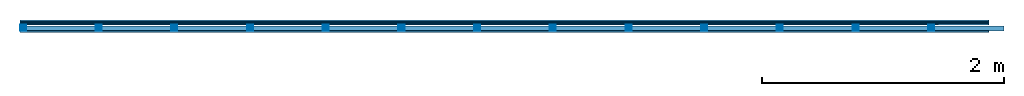
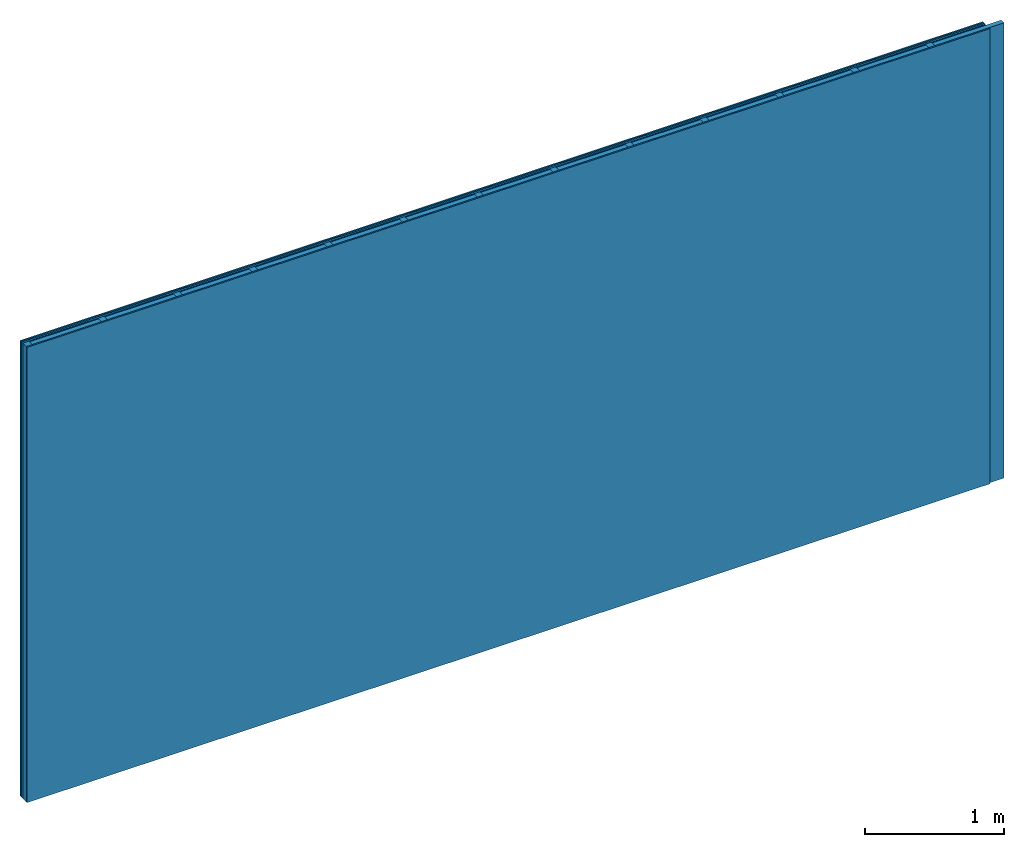
# One storey: 4 plates, 2 members, 1 element without a shape of its own.
"""IFC4 building model written with IfcOpenShell, lengths in metres."""

from ifc_helpers import new_model, si_unit, derived_unit, direction, frame, frame_2d, origin, origin_with_axes, place, context, project, spatial, rectangle, extrude, material, layer, layer_set, type_object, element, aggregate, save


model = new_model("IFC4")

# Units and contexts
plan_context = context("Plan", 3, precision=1e-05, world=origin(), true_north=direction((0.0, 1.0)))
model_context = context("Model", 3, precision=1e-05, world=origin(), true_north=direction((0.0, 1.0)))
ifc_project = project(units=[si_unit("LENGTHUNIT", "METRE"), derived_unit("SOUNDPRESSUREUNIT", [(si_unit("PRESSUREUNIT", "PASCAL", prefix="MICRO"), 0)]), si_unit("ENERGYUNIT", "JOULE", prefix="MEGA"), si_unit("MASSUNIT", "GRAM", prefix="KILO"), derived_unit("THERMALTRANSMITTANCEUNIT", [(si_unit("POWERUNIT", "WATT"), 1), (si_unit("AREAUNIT", "SQUARE_METRE"), -1), (si_unit("THERMODYNAMICTEMPERATUREUNIT", "KELVIN"), -1)]), derived_unit("AREADENSITYUNIT", [(si_unit("MASSUNIT", "GRAM", prefix="KILO"), 1), (si_unit("AREAUNIT", "SQUARE_METRE"), -1)]), derived_unit("USERDEFINED", [(si_unit("ENERGYUNIT", "JOULE", prefix="MEGA"), 1), (si_unit("AREAUNIT", "SQUARE_METRE"), -1)])], contexts=[plan_context, model_context])

# Site, building, storey
site = spatial("IfcSite", under=ifc_project)
building_placement = place(None, origin())
building = spatial("IfcBuilding", under=site, at=building_placement)
storey_placement = place(building_placement, origin())
storey = spatial("IfcBuildingStorey", under=building, at=storey_placement)

# Wall, members, plates
ifc_material_1 = material(Name="joints", Category="04.017")
ifc_layer_1 = layer(ifc_material_1, 0.0, Name="Surface")
ifc_material_2 = material(Name="Plasterboard type A", Category="03.008")
ifc_layer_2 = layer(ifc_material_2, 0.0125, Name="Cover 1st layer")
ifc_layer_3 = layer(ifc_material_2, 0.0125, Name="2nd layer")
ifc_material_3 = material(Name="Phone PLUS TRI", Category="03.013")
ifc_layer_4 = layer(ifc_material_3, 0.015, Name="1st layer")
ifc_material_4 = material(Name="of the art")
ifc_layer_5 = layer(ifc_material_4, 0.0, Name="Bond")
ifc_layer_6 = layer(None, 0.05, Name="Support")
ifc_layer_7 = layer(ifc_material_4, 0.0, Name="Bond")
ifc_layer_8 = layer(ifc_material_2, 0.0125, Name="1st layer")
ifc_layer_9 = layer(ifc_material_1, 0.0, Name="Surface")
ifc_layer_set = layer_set([ifc_layer_1, ifc_layer_2, ifc_layer_3, ifc_layer_4, ifc_layer_5, ifc_layer_6, ifc_layer_7, ifc_layer_8, ifc_layer_9])
wall_type = type_object("IfcWallType", Name="C0458", PredefinedType="NOTDEFINED", material=ifc_layer_set)
wall_placement = place(None, frame((0.0, 0.0, 0.0), z_axis=(0.0, -1.0, 0.0), x_axis=(1.0, 0.0, 0.0)))
wall = element("IfcWall", 1, at=wall_placement, inside=storey, type_object=wall_type, material=ifc_layer_set, Name="Wall #1")
ifc_material_5 = material()
member_1_placement = place(wall_placement, origin())
member_1 = element("IfcMember", 2, at=member_1_placement, material=ifc_material_5, Name="Support", context=plan_context, shape_type="SweptSolid", body=[
    extrude(rectangle(XDim=0.05, YDim=0.05, at=frame_2d((0.025, 0.025), x_axis=(1.0, 0.0))), frame((0.0, 4.0, 0.04), z_axis=(0.0, -1.0, 0.0), x_axis=(1.0, 0.0, 0.0)), (0.0, 0.0, 1.0), 4.0),
    extrude(rectangle(XDim=0.05, YDim=0.05, at=frame_2d((0.025, 0.025), x_axis=(1.0, 0.0))), frame((0.625, 4.0, 0.04), z_axis=(0.0, -1.0, 0.0), x_axis=(1.0, 0.0, 0.0)), (0.0, 0.0, 1.0), 4.0),
    extrude(rectangle(XDim=0.05, YDim=0.05, at=frame_2d((0.025, 0.025), x_axis=(1.0, 0.0))), frame((1.25, 4.0, 0.04), z_axis=(0.0, -1.0, 0.0), x_axis=(1.0, 0.0, 0.0)), (0.0, 0.0, 1.0), 4.0),
    extrude(rectangle(XDim=0.05, YDim=0.05, at=frame_2d((0.025, 0.025), x_axis=(1.0, 0.0))), frame((1.875, 4.0, 0.04), z_axis=(0.0, -1.0, 0.0), x_axis=(1.0, 0.0, 0.0)), (0.0, 0.0, 1.0), 4.0),
    extrude(rectangle(XDim=0.05, YDim=0.05, at=frame_2d((0.025, 0.025), x_axis=(1.0, 0.0))), frame((2.5, 4.0, 0.04), z_axis=(0.0, -1.0, 0.0), x_axis=(1.0, 0.0, 0.0)), (0.0, 0.0, 1.0), 4.0),
    extrude(rectangle(XDim=0.05, YDim=0.05, at=frame_2d((0.025, 0.025), x_axis=(1.0, 0.0))), frame((3.125, 4.0, 0.04), z_axis=(0.0, -1.0, 0.0), x_axis=(1.0, 0.0, 0.0)), (0.0, 0.0, 1.0), 4.0),
    extrude(rectangle(XDim=0.05, YDim=0.05, at=frame_2d((0.025, 0.025), x_axis=(1.0, 0.0))), frame((3.75, 4.0, 0.04), z_axis=(0.0, -1.0, 0.0), x_axis=(1.0, 0.0, 0.0)), (0.0, 0.0, 1.0), 4.0),
    extrude(rectangle(XDim=0.05, YDim=0.05, at=frame_2d((0.025, 0.025), x_axis=(1.0, 0.0))), frame((4.375, 4.0, 0.04), z_axis=(0.0, -1.0, 0.0), x_axis=(1.0, 0.0, 0.0)), (0.0, 0.0, 1.0), 4.0),
    extrude(rectangle(XDim=0.05, YDim=0.05, at=frame_2d((0.025, 0.025), x_axis=(1.0, 0.0))), frame((5.0, 4.0, 0.04), z_axis=(0.0, -1.0, 0.0), x_axis=(1.0, 0.0, 0.0)), (0.0, 0.0, 1.0), 4.0),
    extrude(rectangle(XDim=0.05, YDim=0.05, at=frame_2d((0.025, 0.025), x_axis=(1.0, 0.0))), frame((5.625, 4.0, 0.04), z_axis=(0.0, -1.0, 0.0), x_axis=(1.0, 0.0, 0.0)), (0.0, 0.0, 1.0), 4.0),
    extrude(rectangle(XDim=0.05, YDim=0.05, at=frame_2d((0.025, 0.025), x_axis=(1.0, 0.0))), frame((6.25, 4.0, 0.04), z_axis=(0.0, -1.0, 0.0), x_axis=(1.0, 0.0, 0.0)), (0.0, 0.0, 1.0), 4.0),
    extrude(rectangle(XDim=0.05, YDim=0.05, at=frame_2d((0.025, 0.025), x_axis=(1.0, 0.0))), frame((6.875, 4.0, 0.04), z_axis=(0.0, -1.0, 0.0), x_axis=(1.0, 0.0, 0.0)), (0.0, 0.0, 1.0), 4.0),
    extrude(rectangle(XDim=0.05, YDim=0.05, at=frame_2d((0.025, 0.025), x_axis=(1.0, 0.0))), frame((7.5, 4.0, 0.04), z_axis=(0.0, -1.0, 0.0), x_axis=(1.0, 0.0, 0.0)), (0.0, 0.0, 1.0), 4.0),
])
ifc_material_6 = material()
member_2_placement = place(wall_placement, origin())
member_2 = element("IfcMember", 3, at=member_2_placement, material=ifc_material_6, Name="Cavity", context=plan_context, shape_type="SweptSolid", body=[
    extrude(rectangle(XDim=0.575, YDim=0.04, at=frame_2d((0.2875, 0.02), x_axis=(1.0, 0.0))), frame((0.05, 4.0, 0.05), z_axis=(0.0, -1.0, 0.0), x_axis=(1.0, 0.0, 0.0)), (0.0, 0.0, 1.0), 4.0),
    extrude(rectangle(XDim=0.575, YDim=0.04, at=frame_2d((0.2875, 0.02), x_axis=(1.0, 0.0))), frame((0.675, 4.0, 0.05), z_axis=(0.0, -1.0, 0.0), x_axis=(1.0, 0.0, 0.0)), (0.0, 0.0, 1.0), 4.0),
    extrude(rectangle(XDim=0.575, YDim=0.04, at=frame_2d((0.2875, 0.02), x_axis=(1.0, 0.0))), frame((1.3, 4.0, 0.05), z_axis=(0.0, -1.0, 0.0), x_axis=(1.0, 0.0, 0.0)), (0.0, 0.0, 1.0), 4.0),
    extrude(rectangle(XDim=0.575, YDim=0.04, at=frame_2d((0.2875, 0.02), x_axis=(1.0, 0.0))), frame((1.925, 4.0, 0.05), z_axis=(0.0, -1.0, 0.0), x_axis=(1.0, 0.0, 0.0)), (0.0, 0.0, 1.0), 4.0),
    extrude(rectangle(XDim=0.575, YDim=0.04, at=frame_2d((0.2875, 0.02), x_axis=(1.0, 0.0))), frame((2.55, 4.0, 0.05), z_axis=(0.0, -1.0, 0.0), x_axis=(1.0, 0.0, 0.0)), (0.0, 0.0, 1.0), 4.0),
    extrude(rectangle(XDim=0.575, YDim=0.04, at=frame_2d((0.2875, 0.02), x_axis=(1.0, 0.0))), frame((3.175, 4.0, 0.05), z_axis=(0.0, -1.0, 0.0), x_axis=(1.0, 0.0, 0.0)), (0.0, 0.0, 1.0), 4.0),
    extrude(rectangle(XDim=0.575, YDim=0.04, at=frame_2d((0.2875, 0.02), x_axis=(1.0, 0.0))), frame((3.8, 4.0, 0.05), z_axis=(0.0, -1.0, 0.0), x_axis=(1.0, 0.0, 0.0)), (0.0, 0.0, 1.0), 4.0),
    extrude(rectangle(XDim=0.575, YDim=0.04, at=frame_2d((0.2875, 0.02), x_axis=(1.0, 0.0))), frame((4.425, 4.0, 0.05), z_axis=(0.0, -1.0, 0.0), x_axis=(1.0, 0.0, 0.0)), (0.0, 0.0, 1.0), 4.0),
    extrude(rectangle(XDim=0.575, YDim=0.04, at=frame_2d((0.2875, 0.02), x_axis=(1.0, 0.0))), frame((5.05, 4.0, 0.05), z_axis=(0.0, -1.0, 0.0), x_axis=(1.0, 0.0, 0.0)), (0.0, 0.0, 1.0), 4.0),
    extrude(rectangle(XDim=0.575, YDim=0.04, at=frame_2d((0.2875, 0.02), x_axis=(1.0, 0.0))), frame((5.675, 4.0, 0.05), z_axis=(0.0, -1.0, 0.0), x_axis=(1.0, 0.0, 0.0)), (0.0, 0.0, 1.0), 4.0),
    extrude(rectangle(XDim=0.575, YDim=0.04, at=frame_2d((0.2875, 0.02), x_axis=(1.0, 0.0))), frame((6.3, 4.0, 0.05), z_axis=(0.0, -1.0, 0.0), x_axis=(1.0, 0.0, 0.0)), (0.0, 0.0, 1.0), 4.0),
    extrude(rectangle(XDim=0.575, YDim=0.04, at=frame_2d((0.2875, 0.02), x_axis=(1.0, 0.0))), frame((6.925, 4.0, 0.05), z_axis=(0.0, -1.0, 0.0), x_axis=(1.0, 0.0, 0.0)), (0.0, 0.0, 1.0), 4.0),
    extrude(rectangle(XDim=0.575, YDim=0.04, at=frame_2d((0.2875, 0.02), x_axis=(1.0, 0.0))), frame((7.55, 4.0, 0.05), z_axis=(0.0, -1.0, 0.0), x_axis=(1.0, 0.0, 0.0)), (0.0, 0.0, 1.0), 4.0),
])
plate_1_placement = place(wall_placement, origin())
plate_1 = element("IfcPlate", 4, at=plate_1_placement, material=ifc_material_2, Name="Cover 1st layer", context=plan_context, shape_type="SweptSolid", body=[
    extrude(rectangle(XDim=8.0, YDim=4.0, at=frame_2d((4.0, 2.0), x_axis=(1.0, 0.0))), origin_with_axes(), (0.0, 0.0, 1.0), 0.0125),
])
plate_2_placement = place(wall_placement, origin())
plate_2 = element("IfcPlate", 5, at=plate_2_placement, material=ifc_material_2, Name="2nd layer", context=plan_context, shape_type="SweptSolid", body=[
    extrude(rectangle(XDim=8.0, YDim=4.0, at=frame_2d((4.0, 2.0), x_axis=(1.0, 0.0))), frame((0.0, 0.0, 0.0125), z_axis=(0.0, 0.0, 1.0), x_axis=(1.0, 0.0, 0.0)), (0.0, 0.0, 1.0), 0.0125),
])
plate_3_placement = place(wall_placement, origin())
plate_3 = element("IfcPlate", 6, at=plate_3_placement, material=ifc_material_3, Name="1st layer", context=plan_context, shape_type="SweptSolid", body=[
    extrude(rectangle(XDim=8.0, YDim=4.0, at=frame_2d((4.0, 2.0), x_axis=(1.0, 0.0))), frame((0.0, 0.0, 0.025), z_axis=(0.0, 0.0, 1.0), x_axis=(1.0, 0.0, 0.0)), (0.0, 0.0, 1.0), 0.015),
])
plate_4_placement = place(wall_placement, origin())
plate_4 = element("IfcPlate", 7, at=plate_4_placement, material=ifc_material_2, Name="1st layer", context=plan_context, shape_type="SweptSolid", body=[
    extrude(rectangle(XDim=8.0, YDim=4.0, at=frame_2d((4.0, 2.0), x_axis=(1.0, 0.0))), frame((0.0, 0.0, 0.09), z_axis=(0.0, 0.0, 1.0), x_axis=(1.0, 0.0, 0.0)), (0.0, 0.0, 1.0), 0.0125),
])
aggregate(wall, [plate_1, plate_2, plate_3, member_1, member_2, plate_4])

save(model, "model.ifc")
